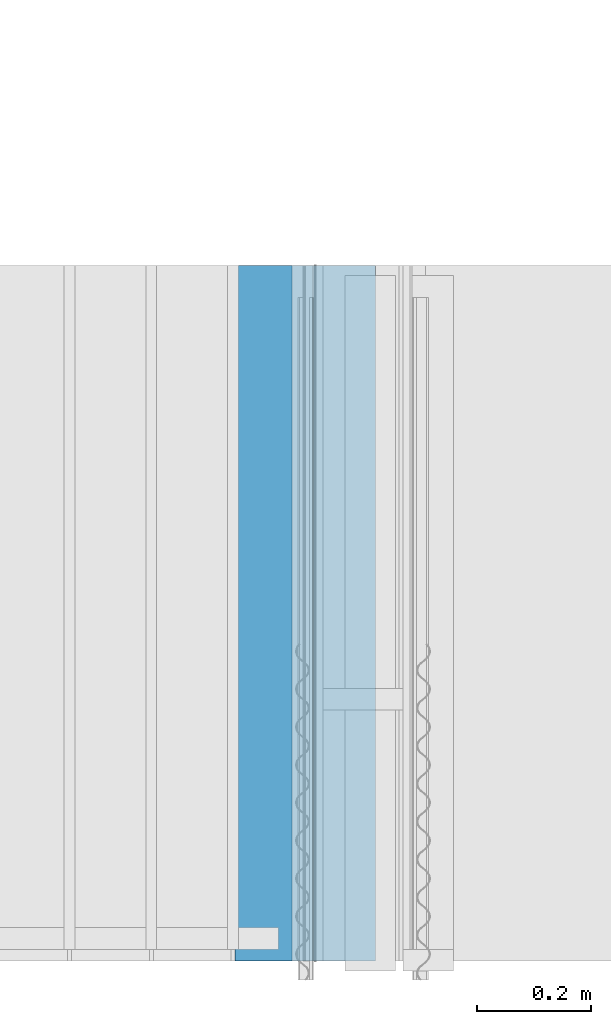
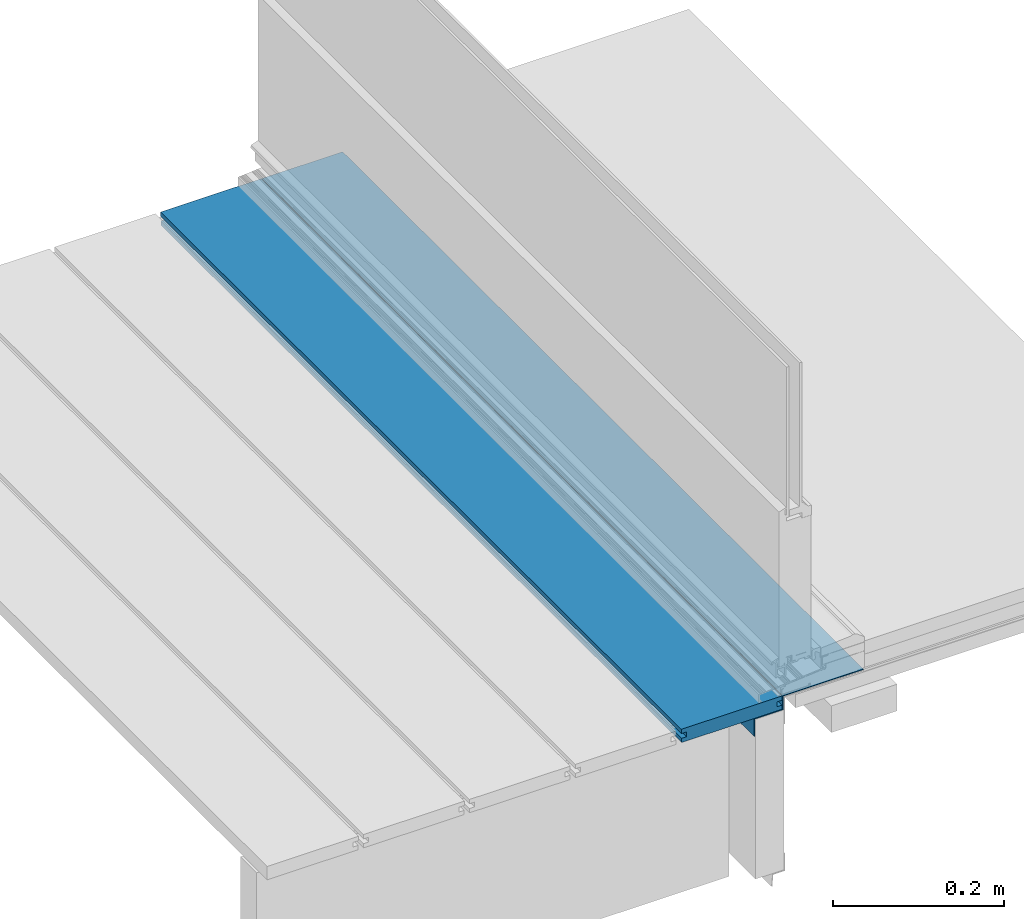
# One storey, part 4 of 33: 2 walls.
"""IFC4 building model written with IfcOpenShell, lengths in feet."""

from ifc_helpers import new_model, entity, si_unit, converted_unit, derived_unit, direction, frame, origin, place, context, subcontext, project, spatial, material, type_object, element, save


model = new_model("IFC4")

# Units and contexts
model_context = context("Model", 3, precision=0.0001, world=origin(), true_north=direction((6.12303176911189e-17, 1.0)))
body_context = subcontext(model_context, "Body", "Model", "MODEL_VIEW")
ifc_project = project(units=[converted_unit("LENGTHUNIT", "FOOT", entity("IfcRatioMeasure", 0.3048), si_unit("LENGTHUNIT", "METRE"), dimensions=[1, 0, 0, 0, 0, 0, 0]), converted_unit("AREAUNIT", "SQUARE FOOT", entity("IfcRatioMeasure", 0.09290304), si_unit("AREAUNIT", "SQUARE_METRE"), dimensions=[2, 0, 0, 0, 0, 0, 0]), converted_unit("VOLUMEUNIT", "CUBIC FOOT", entity("IfcRatioMeasure", 0.028316846592), si_unit("VOLUMEUNIT", "CUBIC_METRE"), dimensions=[3, 0, 0, 0, 0, 0, 0]), converted_unit("PLANEANGLEUNIT", "DEGREE", entity("IfcRatioMeasure", 0.0174532925199433), si_unit("PLANEANGLEUNIT", "RADIAN"), dimensions=[0, 0, 0, 0, 0, 0, 0]), si_unit("MASSUNIT", "GRAM", prefix="KILO"), derived_unit("MASSDENSITYUNIT", [(si_unit("MASSUNIT", "GRAM", prefix="KILO"), 1), (si_unit("LENGTHUNIT", "METRE"), -3)]), derived_unit("MOMENTOFINERTIAUNIT", [(si_unit("LENGTHUNIT", "METRE"), 4)]), si_unit("TIMEUNIT", "SECOND"), si_unit("FREQUENCYUNIT", "HERTZ"), si_unit("THERMODYNAMICTEMPERATUREUNIT", "DEGREE_CELSIUS"), derived_unit("THERMALTRANSMITTANCEUNIT", [(si_unit("MASSUNIT", "GRAM", prefix="KILO"), 1), (si_unit("THERMODYNAMICTEMPERATUREUNIT", "KELVIN"), -1), (si_unit("TIMEUNIT", "SECOND"), -3)]), derived_unit("VOLUMETRICFLOWRATEUNIT", [(si_unit("LENGTHUNIT", "METRE"), 3), (si_unit("TIMEUNIT", "SECOND"), -1)]), si_unit("ELECTRICCURRENTUNIT", "AMPERE"), si_unit("ELECTRICVOLTAGEUNIT", "VOLT"), si_unit("POWERUNIT", "WATT"), si_unit("FORCEUNIT", "NEWTON"), si_unit("ILLUMINANCEUNIT", "LUX"), si_unit("LUMINOUSFLUXUNIT", "LUMEN"), si_unit("LUMINOUSINTENSITYUNIT", "CANDELA"), derived_unit("USERDEFINED", [(si_unit("MASSUNIT", "GRAM", prefix="KILO"), -1), (si_unit("LENGTHUNIT", "METRE"), -2), (si_unit("TIMEUNIT", "SECOND"), 3), (si_unit("LUMINOUSFLUXUNIT", "LUMEN"), 1)]), derived_unit("LINEARVELOCITYUNIT", [(si_unit("LENGTHUNIT", "METRE"), 1), (si_unit("TIMEUNIT", "SECOND"), -1)]), si_unit("PRESSUREUNIT", "PASCAL"), derived_unit("USERDEFINED", [(si_unit("LENGTHUNIT", "METRE"), -2), (si_unit("MASSUNIT", "GRAM", prefix="KILO"), 1), (si_unit("TIMEUNIT", "SECOND"), -2)]), derived_unit("LINEARFORCEUNIT", [(si_unit("MASSUNIT", "GRAM", prefix="KILO"), 1), (si_unit("LENGTHUNIT", "METRE"), 1), (si_unit("TIMEUNIT", "SECOND"), -2), (si_unit("LENGTHUNIT", "METRE"), -1)]), derived_unit("PLANARFORCEUNIT", [(si_unit("MASSUNIT", "GRAM", prefix="KILO"), 1), (si_unit("LENGTHUNIT", "METRE"), 1), (si_unit("TIMEUNIT", "SECOND"), -2), (si_unit("LENGTHUNIT", "METRE"), -2)])], contexts=[model_context])

# Site, building, storey
site_placement = place(None, origin())
site = spatial("IfcSite", under=ifc_project, at=site_placement, CompositionType="ELEMENT")
building_placement = place(site_placement, origin())
building = spatial("IfcBuilding", under=site, at=building_placement, CompositionType="ELEMENT")
storey_placement = place(building_placement, frame((0.0, 0.0, 10.0)))
storey = spatial("IfcBuildingStorey", under=building, at=storey_placement, Name="2ND FLOOR", CompositionType="ELEMENT", Elevation=10.0000000000002)

# Walls
ifc_material_1 = material(Name="COMPOSITE DECKING W/ HIDDEN FASTENERS", Category="Materials")
wall_type_1 = type_object("IfcWallType", Name="Generic Models 647:Generic Models 1", PredefinedType="NOTDEFINED", material=ifc_material_1)
wall_1_placement = place(storey_placement, frame((1458.80381766327, 2.0, 0.618921366607443), z_axis=(0.0, 0.0, 1.0), x_axis=(0.0, 1.0, 0.0)))
cartesian_point_1 = entity("IfcCartesianPoint", [4.0, -0.446740923891412, 0.0])
vertex_point_1 = entity("IfcVertexPoint", cartesian_point_1)
cartesian_point_2 = entity("IfcCartesianPoint", [4.0, -0.00132475379450625, 0.0])
vertex_point_2 = entity("IfcVertexPoint", cartesian_point_2)
ifc_direction_1 = entity("IfcDirection", [0.0, 1.0, 0.0])
edge_curve_1 = entity("IfcEdgeCurve", vertex_point_1, vertex_point_2, entity("IfcTrimmedCurve", entity("IfcLine", cartesian_point_1, entity("IfcVector", ifc_direction_1, 1.0)), [cartesian_point_1], [cartesian_point_2], True, "CARTESIAN"), True)
cartesian_point_3 = entity("IfcCartesianPoint", [4.0, -0.00132475379450625, 0.0198779960861479])
vertex_point_3 = entity("IfcVertexPoint", cartesian_point_3)
ifc_direction_2 = entity("IfcDirection", [0.0, 0.0, 1.0])
edge_curve_2 = entity("IfcEdgeCurve", vertex_point_2, vertex_point_3, entity("IfcTrimmedCurve", entity("IfcLine", cartesian_point_2, entity("IfcVector", ifc_direction_2, 1.0)), [cartesian_point_2], [cartesian_point_3], True, "CARTESIAN"), True)
cartesian_point_4 = entity("IfcCartesianPoint", [4.0, -0.0228400010807945, 0.0198779960861479])
vertex_point_4 = entity("IfcVertexPoint", cartesian_point_4)
ifc_direction_3 = entity("IfcDirection", [0.0, -1.0, 0.0])
edge_curve_3 = entity("IfcEdgeCurve", vertex_point_3, vertex_point_4, entity("IfcTrimmedCurve", entity("IfcLine", cartesian_point_3, entity("IfcVector", ifc_direction_3, 1.0)), [cartesian_point_3], [cartesian_point_4], True, "CARTESIAN"), True)
cartesian_point_5 = entity("IfcCartesianPoint", [4.0, -0.0228400010807945, 0.0422987663426522])
vertex_point_5 = entity("IfcVertexPoint", cartesian_point_5)
edge_curve_4 = entity("IfcEdgeCurve", vertex_point_4, vertex_point_5, entity("IfcTrimmedCurve", entity("IfcLine", cartesian_point_4, entity("IfcVector", ifc_direction_2, 1.0)), [cartesian_point_4], [cartesian_point_5], True, "CARTESIAN"), True)
cartesian_point_6 = entity("IfcCartesianPoint", [4.0, 0.0, 0.0422987663426522])
vertex_point_6 = entity("IfcVertexPoint", cartesian_point_6)
edge_curve_5 = entity("IfcEdgeCurve", vertex_point_5, vertex_point_6, entity("IfcTrimmedCurve", entity("IfcLine", cartesian_point_5, entity("IfcVector", ifc_direction_1, 1.0)), [cartesian_point_5], [cartesian_point_6], True, "CARTESIAN"), True)
cartesian_point_7 = entity("IfcCartesianPoint", [4.0, 0.0, 0.0625000000000551])
vertex_point_7 = entity("IfcVertexPoint", cartesian_point_7)
edge_curve_6 = entity("IfcEdgeCurve", vertex_point_6, vertex_point_7, entity("IfcTrimmedCurve", entity("IfcLine", cartesian_point_6, entity("IfcVector", ifc_direction_2, 1.0)), [cartesian_point_6], [cartesian_point_7], True, "CARTESIAN"), True)
cartesian_point_8 = entity("IfcCartesianPoint", [4.0, -0.446740923891639, 0.0625])
vertex_point_8 = entity("IfcVertexPoint", cartesian_point_8)
edge_curve_7 = entity("IfcEdgeCurve", vertex_point_7, vertex_point_8, entity("IfcTrimmedCurve", entity("IfcLine", cartesian_point_7, entity("IfcVector", ifc_direction_3, 1.0)), [cartesian_point_7], [cartesian_point_8], True, "CARTESIAN"), True)
cartesian_point_9 = entity("IfcCartesianPoint", [4.0, -0.446740923891639, 0.0422987663426522])
vertex_point_9 = entity("IfcVertexPoint", cartesian_point_9)
ifc_direction_4 = entity("IfcDirection", [0.0, 0.0, -1.0])
edge_curve_8 = entity("IfcEdgeCurve", vertex_point_8, vertex_point_9, entity("IfcTrimmedCurve", entity("IfcLine", cartesian_point_8, entity("IfcVector", ifc_direction_4, 1.0)), [cartesian_point_8], [cartesian_point_9], True, "CARTESIAN"), True)
cartesian_point_10 = entity("IfcCartesianPoint", [4.0, -0.423900922810617, 0.0422987663426522])
vertex_point_10 = entity("IfcVertexPoint", cartesian_point_10)
edge_curve_9 = entity("IfcEdgeCurve", vertex_point_9, vertex_point_10, entity("IfcTrimmedCurve", entity("IfcLine", cartesian_point_9, entity("IfcVector", ifc_direction_1, 1.0)), [cartesian_point_9], [cartesian_point_10], True, "CARTESIAN"), True)
cartesian_point_11 = entity("IfcCartesianPoint", [4.0, -0.423900922810617, 0.0198779960861479])
vertex_point_11 = entity("IfcVertexPoint", cartesian_point_11)
edge_curve_10 = entity("IfcEdgeCurve", vertex_point_10, vertex_point_11, entity("IfcTrimmedCurve", entity("IfcLine", cartesian_point_10, entity("IfcVector", ifc_direction_4, 1.0)), [cartesian_point_10], [cartesian_point_11], True, "CARTESIAN"), True)
cartesian_point_12 = entity("IfcCartesianPoint", [4.0, -0.446740923891412, 0.0198779960861479])
vertex_point_12 = entity("IfcVertexPoint", cartesian_point_12)
edge_curve_11 = entity("IfcEdgeCurve", vertex_point_11, vertex_point_12, entity("IfcTrimmedCurve", entity("IfcLine", cartesian_point_11, entity("IfcVector", ifc_direction_3, 1.0)), [cartesian_point_11], [cartesian_point_12], True, "CARTESIAN"), True)
edge_curve_12 = entity("IfcEdgeCurve", vertex_point_12, vertex_point_1, entity("IfcTrimmedCurve", entity("IfcLine", cartesian_point_12, entity("IfcVector", ifc_direction_4, 1.0)), [cartesian_point_12], [cartesian_point_1], True, "CARTESIAN"), True)
ifc_direction_5 = entity("IfcDirection", [1.0, 0.0, 0.0])
cartesian_point_13 = entity("IfcCartesianPoint", [0.0, -0.446740923891412, 0.0])
vertex_point_13 = entity("IfcVertexPoint", cartesian_point_13)
cartesian_point_14 = entity("IfcCartesianPoint", [0.0, -0.446740923891412, 0.0198779960861479])
vertex_point_14 = entity("IfcVertexPoint", cartesian_point_14)
edge_curve_13 = entity("IfcEdgeCurve", vertex_point_13, vertex_point_14, entity("IfcTrimmedCurve", entity("IfcLine", cartesian_point_13, entity("IfcVector", ifc_direction_2, 1.0)), [cartesian_point_13], [cartesian_point_14], True, "CARTESIAN"), True)
cartesian_point_15 = entity("IfcCartesianPoint", [0.0, -0.423900922810617, 0.0198779960861479])
vertex_point_15 = entity("IfcVertexPoint", cartesian_point_15)
edge_curve_14 = entity("IfcEdgeCurve", vertex_point_14, vertex_point_15, entity("IfcTrimmedCurve", entity("IfcLine", cartesian_point_14, entity("IfcVector", ifc_direction_1, 1.0)), [cartesian_point_14], [cartesian_point_15], True, "CARTESIAN"), True)
cartesian_point_16 = entity("IfcCartesianPoint", [0.0, -0.423900922810617, 0.0422987663426522])
vertex_point_16 = entity("IfcVertexPoint", cartesian_point_16)
edge_curve_15 = entity("IfcEdgeCurve", vertex_point_15, vertex_point_16, entity("IfcTrimmedCurve", entity("IfcLine", cartesian_point_15, entity("IfcVector", ifc_direction_2, 1.0)), [cartesian_point_15], [cartesian_point_16], True, "CARTESIAN"), True)
cartesian_point_17 = entity("IfcCartesianPoint", [0.0, -0.446740923891639, 0.0422987663426522])
vertex_point_17 = entity("IfcVertexPoint", cartesian_point_17)
edge_curve_16 = entity("IfcEdgeCurve", vertex_point_16, vertex_point_17, entity("IfcTrimmedCurve", entity("IfcLine", cartesian_point_16, entity("IfcVector", ifc_direction_3, 1.0)), [cartesian_point_16], [cartesian_point_17], True, "CARTESIAN"), True)
cartesian_point_18 = entity("IfcCartesianPoint", [0.0, -0.446740923891639, 0.0625])
vertex_point_18 = entity("IfcVertexPoint", cartesian_point_18)
edge_curve_17 = entity("IfcEdgeCurve", vertex_point_17, vertex_point_18, entity("IfcTrimmedCurve", entity("IfcLine", cartesian_point_17, entity("IfcVector", ifc_direction_2, 1.0)), [cartesian_point_17], [cartesian_point_18], True, "CARTESIAN"), True)
cartesian_point_19 = entity("IfcCartesianPoint", [0.0, 0.0, 0.0625000000000551])
vertex_point_19 = entity("IfcVertexPoint", cartesian_point_19)
edge_curve_18 = entity("IfcEdgeCurve", vertex_point_18, vertex_point_19, entity("IfcTrimmedCurve", entity("IfcLine", cartesian_point_18, entity("IfcVector", ifc_direction_1, 1.0)), [cartesian_point_18], [cartesian_point_19], True, "CARTESIAN"), True)
cartesian_point_20 = entity("IfcCartesianPoint", [0.0, 0.0, 0.0422987663426522])
vertex_point_20 = entity("IfcVertexPoint", cartesian_point_20)
edge_curve_19 = entity("IfcEdgeCurve", vertex_point_19, vertex_point_20, entity("IfcTrimmedCurve", entity("IfcLine", cartesian_point_19, entity("IfcVector", ifc_direction_4, 1.0)), [cartesian_point_19], [cartesian_point_20], True, "CARTESIAN"), True)
cartesian_point_21 = entity("IfcCartesianPoint", [0.0, -0.0228400010807945, 0.0422987663426522])
vertex_point_21 = entity("IfcVertexPoint", cartesian_point_21)
edge_curve_20 = entity("IfcEdgeCurve", vertex_point_20, vertex_point_21, entity("IfcTrimmedCurve", entity("IfcLine", cartesian_point_20, entity("IfcVector", ifc_direction_3, 1.0)), [cartesian_point_20], [cartesian_point_21], True, "CARTESIAN"), True)
cartesian_point_22 = entity("IfcCartesianPoint", [0.0, -0.0228400010807945, 0.0198779960861479])
vertex_point_22 = entity("IfcVertexPoint", cartesian_point_22)
edge_curve_21 = entity("IfcEdgeCurve", vertex_point_21, vertex_point_22, entity("IfcTrimmedCurve", entity("IfcLine", cartesian_point_21, entity("IfcVector", ifc_direction_4, 1.0)), [cartesian_point_21], [cartesian_point_22], True, "CARTESIAN"), True)
cartesian_point_23 = entity("IfcCartesianPoint", [0.0, -0.00132475379450625, 0.0198779960861479])
vertex_point_23 = entity("IfcVertexPoint", cartesian_point_23)
edge_curve_22 = entity("IfcEdgeCurve", vertex_point_22, vertex_point_23, entity("IfcTrimmedCurve", entity("IfcLine", cartesian_point_22, entity("IfcVector", ifc_direction_1, 1.0)), [cartesian_point_22], [cartesian_point_23], True, "CARTESIAN"), True)
cartesian_point_24 = entity("IfcCartesianPoint", [0.0, -0.00132475379450625, 0.0])
vertex_point_24 = entity("IfcVertexPoint", cartesian_point_24)
edge_curve_23 = entity("IfcEdgeCurve", vertex_point_23, vertex_point_24, entity("IfcTrimmedCurve", entity("IfcLine", cartesian_point_23, entity("IfcVector", ifc_direction_4, 1.0)), [cartesian_point_23], [cartesian_point_24], True, "CARTESIAN"), True)
edge_curve_24 = entity("IfcEdgeCurve", vertex_point_24, vertex_point_13, entity("IfcTrimmedCurve", entity("IfcLine", cartesian_point_24, entity("IfcVector", ifc_direction_3, 1.0)), [cartesian_point_24], [cartesian_point_13], True, "CARTESIAN"), True)
ifc_direction_6 = entity("IfcDirection", [-1.0, 0.0, 0.0])
edge_curve_25 = entity("IfcEdgeCurve", vertex_point_13, vertex_point_1, entity("IfcTrimmedCurve", entity("IfcLine", cartesian_point_13, entity("IfcVector", ifc_direction_5, 1.0)), [cartesian_point_13], [cartesian_point_1], True, "CARTESIAN"), True)
edge_curve_26 = entity("IfcEdgeCurve", vertex_point_12, vertex_point_14, entity("IfcTrimmedCurve", entity("IfcLine", cartesian_point_14, entity("IfcVector", ifc_direction_6, 1.0)), [cartesian_point_12], [cartesian_point_14], True, "CARTESIAN"), True)
edge_curve_27 = entity("IfcEdgeCurve", vertex_point_18, vertex_point_8, entity("IfcTrimmedCurve", entity("IfcLine", cartesian_point_18, entity("IfcVector", ifc_direction_5, 1.0)), [cartesian_point_18], [cartesian_point_8], True, "CARTESIAN"), True)
edge_curve_28 = entity("IfcEdgeCurve", vertex_point_7, vertex_point_19, entity("IfcTrimmedCurve", entity("IfcLine", cartesian_point_19, entity("IfcVector", ifc_direction_6, 1.0)), [cartesian_point_7], [cartesian_point_19], True, "CARTESIAN"), True)
edge_curve_29 = entity("IfcEdgeCurve", vertex_point_6, vertex_point_20, entity("IfcTrimmedCurve", entity("IfcLine", cartesian_point_20, entity("IfcVector", ifc_direction_6, 1.0)), [cartesian_point_6], [cartesian_point_20], True, "CARTESIAN"), True)
edge_curve_30 = entity("IfcEdgeCurve", vertex_point_24, vertex_point_2, entity("IfcTrimmedCurve", entity("IfcLine", cartesian_point_24, entity("IfcVector", ifc_direction_5, 1.0)), [cartesian_point_24], [cartesian_point_2], True, "CARTESIAN"), True)
edge_curve_31 = entity("IfcEdgeCurve", vertex_point_17, vertex_point_9, entity("IfcTrimmedCurve", entity("IfcLine", cartesian_point_17, entity("IfcVector", ifc_direction_5, 1.0)), [cartesian_point_17], [cartesian_point_9], True, "CARTESIAN"), True)
edge_curve_32 = entity("IfcEdgeCurve", vertex_point_5, vertex_point_21, entity("IfcTrimmedCurve", entity("IfcLine", cartesian_point_21, entity("IfcVector", ifc_direction_6, 1.0)), [cartesian_point_5], [cartesian_point_21], True, "CARTESIAN"), True)
edge_curve_33 = entity("IfcEdgeCurve", vertex_point_4, vertex_point_22, entity("IfcTrimmedCurve", entity("IfcLine", cartesian_point_22, entity("IfcVector", ifc_direction_6, 1.0)), [cartesian_point_4], [cartesian_point_22], True, "CARTESIAN"), True)
edge_curve_34 = entity("IfcEdgeCurve", vertex_point_3, vertex_point_23, entity("IfcTrimmedCurve", entity("IfcLine", cartesian_point_23, entity("IfcVector", ifc_direction_6, 1.0)), [cartesian_point_3], [cartesian_point_23], True, "CARTESIAN"), True)
edge_curve_35 = entity("IfcEdgeCurve", vertex_point_11, vertex_point_15, entity("IfcTrimmedCurve", entity("IfcLine", cartesian_point_15, entity("IfcVector", ifc_direction_6, 1.0)), [cartesian_point_11], [cartesian_point_15], True, "CARTESIAN"), True)
edge_curve_36 = entity("IfcEdgeCurve", vertex_point_10, vertex_point_16, entity("IfcTrimmedCurve", entity("IfcLine", cartesian_point_16, entity("IfcVector", ifc_direction_6, 1.0)), [cartesian_point_10], [cartesian_point_16], True, "CARTESIAN"), True)
element("IfcWall", 1, at=wall_1_placement, inside=storey, type_object=wall_type_1, material=ifc_material_1, Name="Generic Models 647:Generic Models 1", ObjectType="Generic Models 647:Generic Models 1", PredefinedType="NOTDEFINED", context=body_context, shape_type="AdvancedBrep", body=[
    entity("IfcAdvancedBrep", entity("IfcClosedShell", [entity("IfcAdvancedFace", [entity("IfcFaceOuterBound", entity("IfcEdgeLoop", [entity("IfcOrientedEdge", None, None, edge_curve_1, True), entity("IfcOrientedEdge", None, None, edge_curve_2, True), entity("IfcOrientedEdge", None, None, edge_curve_3, True), entity("IfcOrientedEdge", None, None, edge_curve_4, True), entity("IfcOrientedEdge", None, None, edge_curve_5, True), entity("IfcOrientedEdge", None, None, edge_curve_6, True), entity("IfcOrientedEdge", None, None, edge_curve_7, True), entity("IfcOrientedEdge", None, None, edge_curve_8, True), entity("IfcOrientedEdge", None, None, edge_curve_9, True), entity("IfcOrientedEdge", None, None, edge_curve_10, True), entity("IfcOrientedEdge", None, None, edge_curve_11, True), entity("IfcOrientedEdge", None, None, edge_curve_12, True)]), True)], entity("IfcPlane", entity("IfcAxis2Placement3D", entity("IfcCartesianPoint", [4.0, -0.446740923891412, -0.0208333333328241]), ifc_direction_5, ifc_direction_4)), True), entity("IfcAdvancedFace", [entity("IfcFaceOuterBound", entity("IfcEdgeLoop", [entity("IfcOrientedEdge", None, None, edge_curve_13, True), entity("IfcOrientedEdge", None, None, edge_curve_14, True), entity("IfcOrientedEdge", None, None, edge_curve_15, True), entity("IfcOrientedEdge", None, None, edge_curve_16, True), entity("IfcOrientedEdge", None, None, edge_curve_17, True), entity("IfcOrientedEdge", None, None, edge_curve_18, True), entity("IfcOrientedEdge", None, None, edge_curve_19, True), entity("IfcOrientedEdge", None, None, edge_curve_20, True), entity("IfcOrientedEdge", None, None, edge_curve_21, True), entity("IfcOrientedEdge", None, None, edge_curve_22, True), entity("IfcOrientedEdge", None, None, edge_curve_23, True), entity("IfcOrientedEdge", None, None, edge_curve_24, True)]), True)], entity("IfcPlane", entity("IfcAxis2Placement3D", entity("IfcCartesianPoint", [0.0, -0.446740923891412, -0.0208333333328241]), ifc_direction_6, ifc_direction_2)), True), entity("IfcAdvancedFace", [entity("IfcFaceOuterBound", entity("IfcEdgeLoop", [entity("IfcOrientedEdge", None, None, edge_curve_13, False), entity("IfcOrientedEdge", None, None, edge_curve_25, True), entity("IfcOrientedEdge", None, None, edge_curve_12, False), entity("IfcOrientedEdge", None, None, edge_curve_26, True)]), True)], entity("IfcPlane", entity("IfcAxis2Placement3D", cartesian_point_13, ifc_direction_3, ifc_direction_5)), True), entity("IfcAdvancedFace", [entity("IfcFaceOuterBound", entity("IfcEdgeLoop", [entity("IfcOrientedEdge", None, None, edge_curve_18, False), entity("IfcOrientedEdge", None, None, edge_curve_27, True), entity("IfcOrientedEdge", None, None, edge_curve_7, False), entity("IfcOrientedEdge", None, None, edge_curve_28, True)]), True)], entity("IfcPlane", entity("IfcAxis2Placement3D", cartesian_point_18, ifc_direction_2, ifc_direction_5)), True), entity("IfcAdvancedFace", [entity("IfcFaceOuterBound", entity("IfcEdgeLoop", [entity("IfcOrientedEdge", None, None, edge_curve_19, False), entity("IfcOrientedEdge", None, None, edge_curve_28, False), entity("IfcOrientedEdge", None, None, edge_curve_6, False), entity("IfcOrientedEdge", None, None, edge_curve_29, True)]), True)], entity("IfcPlane", entity("IfcAxis2Placement3D", cartesian_point_19, ifc_direction_1, ifc_direction_5)), True), entity("IfcAdvancedFace", [entity("IfcFaceOuterBound", entity("IfcEdgeLoop", [entity("IfcOrientedEdge", None, None, edge_curve_24, False), entity("IfcOrientedEdge", None, None, edge_curve_30, True), entity("IfcOrientedEdge", None, None, edge_curve_1, False), entity("IfcOrientedEdge", None, None, edge_curve_25, False)]), True)], entity("IfcPlane", entity("IfcAxis2Placement3D", cartesian_point_24, ifc_direction_4, ifc_direction_5)), True), entity("IfcAdvancedFace", [entity("IfcFaceOuterBound", entity("IfcEdgeLoop", [entity("IfcOrientedEdge", None, None, edge_curve_17, False), entity("IfcOrientedEdge", None, None, edge_curve_31, True), entity("IfcOrientedEdge", None, None, edge_curve_8, False), entity("IfcOrientedEdge", None, None, edge_curve_27, False)]), True)], entity("IfcPlane", entity("IfcAxis2Placement3D", cartesian_point_17, ifc_direction_3, ifc_direction_5)), True), entity("IfcAdvancedFace", [entity("IfcFaceOuterBound", entity("IfcEdgeLoop", [entity("IfcOrientedEdge", None, None, edge_curve_20, False), entity("IfcOrientedEdge", None, None, edge_curve_29, False), entity("IfcOrientedEdge", None, None, edge_curve_5, False), entity("IfcOrientedEdge", None, None, edge_curve_32, True)]), True)], entity("IfcPlane", entity("IfcAxis2Placement3D", cartesian_point_20, ifc_direction_4, ifc_direction_5)), True), entity("IfcAdvancedFace", [entity("IfcFaceOuterBound", entity("IfcEdgeLoop", [entity("IfcOrientedEdge", None, None, edge_curve_21, False), entity("IfcOrientedEdge", None, None, edge_curve_32, False), entity("IfcOrientedEdge", None, None, edge_curve_4, False), entity("IfcOrientedEdge", None, None, edge_curve_33, True)]), True)], entity("IfcPlane", entity("IfcAxis2Placement3D", cartesian_point_21, ifc_direction_1, ifc_direction_5)), True), entity("IfcAdvancedFace", [entity("IfcFaceOuterBound", entity("IfcEdgeLoop", [entity("IfcOrientedEdge", None, None, edge_curve_22, False), entity("IfcOrientedEdge", None, None, edge_curve_33, False), entity("IfcOrientedEdge", None, None, edge_curve_3, False), entity("IfcOrientedEdge", None, None, edge_curve_34, True)]), True)], entity("IfcPlane", entity("IfcAxis2Placement3D", cartesian_point_22, ifc_direction_2, ifc_direction_5)), True), entity("IfcAdvancedFace", [entity("IfcFaceOuterBound", entity("IfcEdgeLoop", [entity("IfcOrientedEdge", None, None, edge_curve_23, False), entity("IfcOrientedEdge", None, None, edge_curve_34, False), entity("IfcOrientedEdge", None, None, edge_curve_2, False), entity("IfcOrientedEdge", None, None, edge_curve_30, False)]), True)], entity("IfcPlane", entity("IfcAxis2Placement3D", cartesian_point_23, ifc_direction_1, ifc_direction_5)), True), entity("IfcAdvancedFace", [entity("IfcFaceOuterBound", entity("IfcEdgeLoop", [entity("IfcOrientedEdge", None, None, edge_curve_14, False), entity("IfcOrientedEdge", None, None, edge_curve_26, False), entity("IfcOrientedEdge", None, None, edge_curve_11, False), entity("IfcOrientedEdge", None, None, edge_curve_35, True)]), True)], entity("IfcPlane", entity("IfcAxis2Placement3D", cartesian_point_14, ifc_direction_2, ifc_direction_5)), True), entity("IfcAdvancedFace", [entity("IfcFaceOuterBound", entity("IfcEdgeLoop", [entity("IfcOrientedEdge", None, None, edge_curve_15, False), entity("IfcOrientedEdge", None, None, edge_curve_35, False), entity("IfcOrientedEdge", None, None, edge_curve_10, False), entity("IfcOrientedEdge", None, None, edge_curve_36, True)]), True)], entity("IfcPlane", entity("IfcAxis2Placement3D", cartesian_point_15, ifc_direction_3, ifc_direction_5)), True), entity("IfcAdvancedFace", [entity("IfcFaceOuterBound", entity("IfcEdgeLoop", [entity("IfcOrientedEdge", None, None, edge_curve_16, False), entity("IfcOrientedEdge", None, None, edge_curve_36, False), entity("IfcOrientedEdge", None, None, edge_curve_9, False), entity("IfcOrientedEdge", None, None, edge_curve_31, False)]), True)], entity("IfcPlane", entity("IfcAxis2Placement3D", cartesian_point_16, ifc_direction_4, ifc_direction_5)), True)])),
])
ifc_material_2 = material(Name="METAL FLASHING", Category="Materials")
wall_type_2 = type_object("IfcWallType", Name="Generic Models 670:Generic Models 1", PredefinedType="NOTDEFINED", material=ifc_material_2)
wall_2_placement = place(storey_placement, frame((1459.12681471417, 2.0, 0.534351233082191), z_axis=(0.0, 0.0, 1.0), x_axis=(0.0, 1.0, 0.0)))
cartesian_point_25 = entity("IfcCartesianPoint", [4.0, -0.126086789512556, 0.14698036367813])
vertex_point_25 = entity("IfcVertexPoint", cartesian_point_25)
cartesian_point_26 = entity("IfcCartesianPoint", [4.0, -0.484568282953887, 0.14698036367813])
vertex_point_26 = entity("IfcVertexPoint", cartesian_point_26)
ifc_direction_7 = entity("IfcDirection", [0.0, -1.0, 0.0])
edge_curve_37 = entity("IfcEdgeCurve", vertex_point_25, vertex_point_26, entity("IfcTrimmedCurve", entity("IfcLine", cartesian_point_25, entity("IfcVector", ifc_direction_7, 1.0)), [cartesian_point_25], [cartesian_point_26], True, "CARTESIAN"), True)
cartesian_point_27 = entity("IfcCartesianPoint", [4.0, -0.484568282953887, 0.143725155344796])
vertex_point_27 = entity("IfcVertexPoint", cartesian_point_27)
ifc_direction_8 = entity("IfcDirection", [0.0, 0.0, -1.0])
edge_curve_38 = entity("IfcEdgeCurve", vertex_point_26, vertex_point_27, entity("IfcTrimmedCurve", entity("IfcLine", cartesian_point_26, entity("IfcVector", ifc_direction_8, 1.0)), [cartesian_point_26], [cartesian_point_27], True, "CARTESIAN"), True)
cartesian_point_28 = entity("IfcCartesianPoint", [4.0, -0.129420122845886, 0.143725155344796])
vertex_point_28 = entity("IfcVertexPoint", cartesian_point_28)
ifc_direction_9 = entity("IfcDirection", [0.0, 1.0, 0.0])
edge_curve_39 = entity("IfcEdgeCurve", vertex_point_27, vertex_point_28, entity("IfcTrimmedCurve", entity("IfcLine", cartesian_point_27, entity("IfcVector", ifc_direction_9, 1.0)), [cartesian_point_27], [cartesian_point_28], True, "CARTESIAN"), True)
cartesian_point_29 = entity("IfcCartesianPoint", [4.0, -0.129420122845886, 0.079947113700598])
vertex_point_29 = entity("IfcVertexPoint", cartesian_point_29)
edge_curve_40 = entity("IfcEdgeCurve", vertex_point_28, vertex_point_29, entity("IfcTrimmedCurve", entity("IfcLine", cartesian_point_28, entity("IfcVector", ifc_direction_8, 1.0)), [cartesian_point_28], [cartesian_point_29], True, "CARTESIAN"), True)
cartesian_point_30 = entity("IfcCartesianPoint", [4.0, -0.0033333333333303, 0.079947113700598])
vertex_point_30 = entity("IfcVertexPoint", cartesian_point_30)
edge_curve_41 = entity("IfcEdgeCurve", vertex_point_29, vertex_point_30, entity("IfcTrimmedCurve", entity("IfcLine", cartesian_point_29, entity("IfcVector", ifc_direction_9, 1.0)), [cartesian_point_29], [cartesian_point_30], True, "CARTESIAN"), True)
cartesian_point_31 = entity("IfcCartesianPoint", [4.0, -0.0033333333333303, 0.0])
vertex_point_31 = entity("IfcVertexPoint", cartesian_point_31)
edge_curve_42 = entity("IfcEdgeCurve", vertex_point_30, vertex_point_31, entity("IfcTrimmedCurve", entity("IfcLine", cartesian_point_30, entity("IfcVector", ifc_direction_8, 1.0)), [cartesian_point_30], [cartesian_point_31], True, "CARTESIAN"), True)
cartesian_point_32 = entity("IfcCartesianPoint", [4.0, 0.0, 0.0])
vertex_point_32 = entity("IfcVertexPoint", cartesian_point_32)
edge_curve_43 = entity("IfcEdgeCurve", vertex_point_31, vertex_point_32, entity("IfcTrimmedCurve", entity("IfcLine", cartesian_point_31, entity("IfcVector", ifc_direction_9, 1.0)), [cartesian_point_31], [cartesian_point_32], True, "CARTESIAN"), True)
cartesian_point_33 = entity("IfcCartesianPoint", [4.0, 0.0, 0.0832023220339302])
vertex_point_33 = entity("IfcVertexPoint", cartesian_point_33)
ifc_direction_10 = entity("IfcDirection", [0.0, 0.0, 1.0])
edge_curve_44 = entity("IfcEdgeCurve", vertex_point_32, vertex_point_33, entity("IfcTrimmedCurve", entity("IfcLine", cartesian_point_32, entity("IfcVector", ifc_direction_10, 1.0)), [cartesian_point_32], [cartesian_point_33], True, "CARTESIAN"), True)
cartesian_point_34 = entity("IfcCartesianPoint", [4.0, -0.126086789512556, 0.0832023220339302])
vertex_point_34 = entity("IfcVertexPoint", cartesian_point_34)
edge_curve_45 = entity("IfcEdgeCurve", vertex_point_33, vertex_point_34, entity("IfcTrimmedCurve", entity("IfcLine", cartesian_point_33, entity("IfcVector", ifc_direction_7, 1.0)), [cartesian_point_33], [cartesian_point_34], True, "CARTESIAN"), True)
edge_curve_46 = entity("IfcEdgeCurve", vertex_point_34, vertex_point_25, entity("IfcTrimmedCurve", entity("IfcLine", cartesian_point_34, entity("IfcVector", ifc_direction_10, 1.0)), [cartesian_point_34], [cartesian_point_25], True, "CARTESIAN"), True)
ifc_direction_11 = entity("IfcDirection", [1.0, 0.0, 0.0])
cartesian_point_35 = entity("IfcCartesianPoint", [0.0, -0.126086789512556, 0.146980363678137])
vertex_point_35 = entity("IfcVertexPoint", cartesian_point_35)
cartesian_point_36 = entity("IfcCartesianPoint", [0.0, -0.126086789512556, 0.0832023220339373])
vertex_point_36 = entity("IfcVertexPoint", cartesian_point_36)
edge_curve_47 = entity("IfcEdgeCurve", vertex_point_35, vertex_point_36, entity("IfcTrimmedCurve", entity("IfcLine", cartesian_point_35, entity("IfcVector", ifc_direction_8, 1.0)), [cartesian_point_35], [cartesian_point_36], True, "CARTESIAN"), True)
cartesian_point_37 = entity("IfcCartesianPoint", [0.0, 0.0, 0.0832023220339373])
vertex_point_37 = entity("IfcVertexPoint", cartesian_point_37)
edge_curve_48 = entity("IfcEdgeCurve", vertex_point_36, vertex_point_37, entity("IfcTrimmedCurve", entity("IfcLine", cartesian_point_36, entity("IfcVector", ifc_direction_9, 1.0)), [cartesian_point_36], [cartesian_point_37], True, "CARTESIAN"), True)
cartesian_point_38 = entity("IfcCartesianPoint", [0.0, 0.0, 0.0])
vertex_point_38 = entity("IfcVertexPoint", cartesian_point_38)
edge_curve_49 = entity("IfcEdgeCurve", vertex_point_37, vertex_point_38, entity("IfcTrimmedCurve", entity("IfcLine", cartesian_point_37, entity("IfcVector", ifc_direction_8, 1.0)), [cartesian_point_37], [cartesian_point_38], True, "CARTESIAN"), True)
cartesian_point_39 = entity("IfcCartesianPoint", [0.0, -0.0033333333333303, 0.0])
vertex_point_39 = entity("IfcVertexPoint", cartesian_point_39)
edge_curve_50 = entity("IfcEdgeCurve", vertex_point_38, vertex_point_39, entity("IfcTrimmedCurve", entity("IfcLine", cartesian_point_38, entity("IfcVector", ifc_direction_7, 1.0)), [cartesian_point_38], [cartesian_point_39], True, "CARTESIAN"), True)
cartesian_point_40 = entity("IfcCartesianPoint", [0.0, -0.0033333333333303, 0.0799471137006051])
vertex_point_40 = entity("IfcVertexPoint", cartesian_point_40)
edge_curve_51 = entity("IfcEdgeCurve", vertex_point_39, vertex_point_40, entity("IfcTrimmedCurve", entity("IfcLine", cartesian_point_39, entity("IfcVector", ifc_direction_10, 1.0)), [cartesian_point_39], [cartesian_point_40], True, "CARTESIAN"), True)
cartesian_point_41 = entity("IfcCartesianPoint", [0.0, -0.129420122845886, 0.0799471137006051])
vertex_point_41 = entity("IfcVertexPoint", cartesian_point_41)
edge_curve_52 = entity("IfcEdgeCurve", vertex_point_40, vertex_point_41, entity("IfcTrimmedCurve", entity("IfcLine", cartesian_point_40, entity("IfcVector", ifc_direction_7, 1.0)), [cartesian_point_40], [cartesian_point_41], True, "CARTESIAN"), True)
cartesian_point_42 = entity("IfcCartesianPoint", [0.0, -0.129420122845886, 0.143725155344804])
vertex_point_42 = entity("IfcVertexPoint", cartesian_point_42)
edge_curve_53 = entity("IfcEdgeCurve", vertex_point_41, vertex_point_42, entity("IfcTrimmedCurve", entity("IfcLine", cartesian_point_41, entity("IfcVector", ifc_direction_10, 1.0)), [cartesian_point_41], [cartesian_point_42], True, "CARTESIAN"), True)
cartesian_point_43 = entity("IfcCartesianPoint", [0.0, -0.484568282953887, 0.143725155344804])
vertex_point_43 = entity("IfcVertexPoint", cartesian_point_43)
edge_curve_54 = entity("IfcEdgeCurve", vertex_point_42, vertex_point_43, entity("IfcTrimmedCurve", entity("IfcLine", cartesian_point_42, entity("IfcVector", ifc_direction_7, 1.0)), [cartesian_point_42], [cartesian_point_43], True, "CARTESIAN"), True)
cartesian_point_44 = entity("IfcCartesianPoint", [0.0, -0.484568282953887, 0.146980363678137])
vertex_point_44 = entity("IfcVertexPoint", cartesian_point_44)
edge_curve_55 = entity("IfcEdgeCurve", vertex_point_43, vertex_point_44, entity("IfcTrimmedCurve", entity("IfcLine", cartesian_point_43, entity("IfcVector", ifc_direction_10, 1.0)), [cartesian_point_43], [cartesian_point_44], True, "CARTESIAN"), True)
edge_curve_56 = entity("IfcEdgeCurve", vertex_point_44, vertex_point_35, entity("IfcTrimmedCurve", entity("IfcLine", cartesian_point_44, entity("IfcVector", ifc_direction_9, 1.0)), [cartesian_point_44], [cartesian_point_35], True, "CARTESIAN"), True)
ifc_direction_12 = entity("IfcDirection", [-1.0, 0.0, 0.0])
edge_curve_57 = entity("IfcEdgeCurve", vertex_point_41, vertex_point_29, entity("IfcTrimmedCurve", entity("IfcLine", cartesian_point_41, entity("IfcVector", ifc_direction_11, 1.0)), [cartesian_point_41], [cartesian_point_29], True, "CARTESIAN"), True)
edge_curve_58 = entity("IfcEdgeCurve", vertex_point_28, vertex_point_42, entity("IfcTrimmedCurve", entity("IfcLine", cartesian_point_42, entity("IfcVector", ifc_direction_12, 1.0)), [cartesian_point_28], [cartesian_point_42], True, "CARTESIAN"), True)
edge_curve_59 = entity("IfcEdgeCurve", vertex_point_35, vertex_point_25, entity("IfcTrimmedCurve", entity("IfcLine", cartesian_point_35, entity("IfcVector", ifc_direction_11, 1.0)), [cartesian_point_35], [cartesian_point_25], True, "CARTESIAN"), True)
edge_curve_60 = entity("IfcEdgeCurve", vertex_point_34, vertex_point_36, entity("IfcTrimmedCurve", entity("IfcLine", cartesian_point_36, entity("IfcVector", ifc_direction_12, 1.0)), [cartesian_point_34], [cartesian_point_36], True, "CARTESIAN"), True)
edge_curve_61 = entity("IfcEdgeCurve", vertex_point_27, vertex_point_43, entity("IfcTrimmedCurve", entity("IfcLine", cartesian_point_43, entity("IfcVector", ifc_direction_12, 1.0)), [cartesian_point_27], [cartesian_point_43], True, "CARTESIAN"), True)
edge_curve_62 = entity("IfcEdgeCurve", vertex_point_26, vertex_point_44, entity("IfcTrimmedCurve", entity("IfcLine", cartesian_point_44, entity("IfcVector", ifc_direction_12, 1.0)), [cartesian_point_26], [cartesian_point_44], True, "CARTESIAN"), True)
edge_curve_63 = entity("IfcEdgeCurve", vertex_point_33, vertex_point_37, entity("IfcTrimmedCurve", entity("IfcLine", cartesian_point_37, entity("IfcVector", ifc_direction_12, 1.0)), [cartesian_point_33], [cartesian_point_37], True, "CARTESIAN"), True)
edge_curve_64 = entity("IfcEdgeCurve", vertex_point_32, vertex_point_38, entity("IfcTrimmedCurve", entity("IfcLine", cartesian_point_38, entity("IfcVector", ifc_direction_12, 1.0)), [cartesian_point_32], [cartesian_point_38], True, "CARTESIAN"), True)
edge_curve_65 = entity("IfcEdgeCurve", vertex_point_31, vertex_point_39, entity("IfcTrimmedCurve", entity("IfcLine", cartesian_point_39, entity("IfcVector", ifc_direction_12, 1.0)), [cartesian_point_31], [cartesian_point_39], True, "CARTESIAN"), True)
edge_curve_66 = entity("IfcEdgeCurve", vertex_point_30, vertex_point_40, entity("IfcTrimmedCurve", entity("IfcLine", cartesian_point_40, entity("IfcVector", ifc_direction_12, 1.0)), [cartesian_point_30], [cartesian_point_40], True, "CARTESIAN"), True)
element("IfcWall", 2, at=wall_2_placement, inside=storey, type_object=wall_type_2, material=ifc_material_2, Name="Generic Models 670:Generic Models 1", ObjectType="Generic Models 670:Generic Models 1", PredefinedType="NOTDEFINED", context=body_context, shape_type="AdvancedBrep", body=[
    entity("IfcAdvancedBrep", entity("IfcClosedShell", [entity("IfcAdvancedFace", [entity("IfcFaceOuterBound", entity("IfcEdgeLoop", [entity("IfcOrientedEdge", None, None, edge_curve_37, True), entity("IfcOrientedEdge", None, None, edge_curve_38, True), entity("IfcOrientedEdge", None, None, edge_curve_39, True), entity("IfcOrientedEdge", None, None, edge_curve_40, True), entity("IfcOrientedEdge", None, None, edge_curve_41, True), entity("IfcOrientedEdge", None, None, edge_curve_42, True), entity("IfcOrientedEdge", None, None, edge_curve_43, True), entity("IfcOrientedEdge", None, None, edge_curve_44, True), entity("IfcOrientedEdge", None, None, edge_curve_45, True), entity("IfcOrientedEdge", None, None, edge_curve_46, True)]), True)], entity("IfcPlane", entity("IfcAxis2Placement3D", entity("IfcCartesianPoint", [4.0, -0.126086789512556, -9.90123864102411]), ifc_direction_11, ifc_direction_10)), True), entity("IfcAdvancedFace", [entity("IfcFaceOuterBound", entity("IfcEdgeLoop", [entity("IfcOrientedEdge", None, None, edge_curve_47, True), entity("IfcOrientedEdge", None, None, edge_curve_48, True), entity("IfcOrientedEdge", None, None, edge_curve_49, True), entity("IfcOrientedEdge", None, None, edge_curve_50, True), entity("IfcOrientedEdge", None, None, edge_curve_51, True), entity("IfcOrientedEdge", None, None, edge_curve_52, True), entity("IfcOrientedEdge", None, None, edge_curve_53, True), entity("IfcOrientedEdge", None, None, edge_curve_54, True), entity("IfcOrientedEdge", None, None, edge_curve_55, True), entity("IfcOrientedEdge", None, None, edge_curve_56, True)]), True)], entity("IfcPlane", entity("IfcAxis2Placement3D", entity("IfcCartesianPoint", [0.0, -0.126086789512556, -9.9012386410241]), ifc_direction_12, ifc_direction_8)), True), entity("IfcAdvancedFace", [entity("IfcFaceOuterBound", entity("IfcEdgeLoop", [entity("IfcOrientedEdge", None, None, edge_curve_53, False), entity("IfcOrientedEdge", None, None, edge_curve_57, True), entity("IfcOrientedEdge", None, None, edge_curve_40, False), entity("IfcOrientedEdge", None, None, edge_curve_58, True)]), True)], entity("IfcPlane", entity("IfcAxis2Placement3D", cartesian_point_41, ifc_direction_7, ifc_direction_11)), True), entity("IfcAdvancedFace", [entity("IfcFaceOuterBound", entity("IfcEdgeLoop", [entity("IfcOrientedEdge", None, None, edge_curve_47, False), entity("IfcOrientedEdge", None, None, edge_curve_59, True), entity("IfcOrientedEdge", None, None, edge_curve_46, False), entity("IfcOrientedEdge", None, None, edge_curve_60, True)]), True)], entity("IfcPlane", entity("IfcAxis2Placement3D", cartesian_point_35, ifc_direction_9, ifc_direction_11)), True), entity("IfcAdvancedFace", [entity("IfcFaceOuterBound", entity("IfcEdgeLoop", [entity("IfcOrientedEdge", None, None, edge_curve_54, False), entity("IfcOrientedEdge", None, None, edge_curve_58, False), entity("IfcOrientedEdge", None, None, edge_curve_39, False), entity("IfcOrientedEdge", None, None, edge_curve_61, True)]), True)], entity("IfcPlane", entity("IfcAxis2Placement3D", cartesian_point_42, ifc_direction_8, ifc_direction_11)), True), entity("IfcAdvancedFace", [entity("IfcFaceOuterBound", entity("IfcEdgeLoop", [entity("IfcOrientedEdge", None, None, edge_curve_55, False), entity("IfcOrientedEdge", None, None, edge_curve_61, False), entity("IfcOrientedEdge", None, None, edge_curve_38, False), entity("IfcOrientedEdge", None, None, edge_curve_62, True)]), True)], entity("IfcPlane", entity("IfcAxis2Placement3D", cartesian_point_43, ifc_direction_7, ifc_direction_11)), True), entity("IfcAdvancedFace", [entity("IfcFaceOuterBound", entity("IfcEdgeLoop", [entity("IfcOrientedEdge", None, None, edge_curve_56, False), entity("IfcOrientedEdge", None, None, edge_curve_62, False), entity("IfcOrientedEdge", None, None, edge_curve_37, False), entity("IfcOrientedEdge", None, None, edge_curve_59, False)]), True)], entity("IfcPlane", entity("IfcAxis2Placement3D", cartesian_point_44, ifc_direction_10, ifc_direction_11)), True), entity("IfcAdvancedFace", [entity("IfcFaceOuterBound", entity("IfcEdgeLoop", [entity("IfcOrientedEdge", None, None, edge_curve_48, False), entity("IfcOrientedEdge", None, None, edge_curve_60, False), entity("IfcOrientedEdge", None, None, edge_curve_45, False), entity("IfcOrientedEdge", None, None, edge_curve_63, True)]), True)], entity("IfcPlane", entity("IfcAxis2Placement3D", cartesian_point_36, ifc_direction_10, ifc_direction_11)), True), entity("IfcAdvancedFace", [entity("IfcFaceOuterBound", entity("IfcEdgeLoop", [entity("IfcOrientedEdge", None, None, edge_curve_49, False), entity("IfcOrientedEdge", None, None, edge_curve_63, False), entity("IfcOrientedEdge", None, None, edge_curve_44, False), entity("IfcOrientedEdge", None, None, edge_curve_64, True)]), True)], entity("IfcPlane", entity("IfcAxis2Placement3D", cartesian_point_37, ifc_direction_9, ifc_direction_11)), True), entity("IfcAdvancedFace", [entity("IfcFaceOuterBound", entity("IfcEdgeLoop", [entity("IfcOrientedEdge", None, None, edge_curve_50, False), entity("IfcOrientedEdge", None, None, edge_curve_64, False), entity("IfcOrientedEdge", None, None, edge_curve_43, False), entity("IfcOrientedEdge", None, None, edge_curve_65, True)]), True)], entity("IfcPlane", entity("IfcAxis2Placement3D", cartesian_point_38, ifc_direction_8, ifc_direction_11)), True), entity("IfcAdvancedFace", [entity("IfcFaceOuterBound", entity("IfcEdgeLoop", [entity("IfcOrientedEdge", None, None, edge_curve_51, False), entity("IfcOrientedEdge", None, None, edge_curve_65, False), entity("IfcOrientedEdge", None, None, edge_curve_42, False), entity("IfcOrientedEdge", None, None, edge_curve_66, True)]), True)], entity("IfcPlane", entity("IfcAxis2Placement3D", cartesian_point_39, ifc_direction_7, ifc_direction_11)), True), entity("IfcAdvancedFace", [entity("IfcFaceOuterBound", entity("IfcEdgeLoop", [entity("IfcOrientedEdge", None, None, edge_curve_52, False), entity("IfcOrientedEdge", None, None, edge_curve_66, False), entity("IfcOrientedEdge", None, None, edge_curve_41, False), entity("IfcOrientedEdge", None, None, edge_curve_57, False)]), True)], entity("IfcPlane", entity("IfcAxis2Placement3D", cartesian_point_40, ifc_direction_8, ifc_direction_11)), True)])),
])

save(model, "model.ifc")
